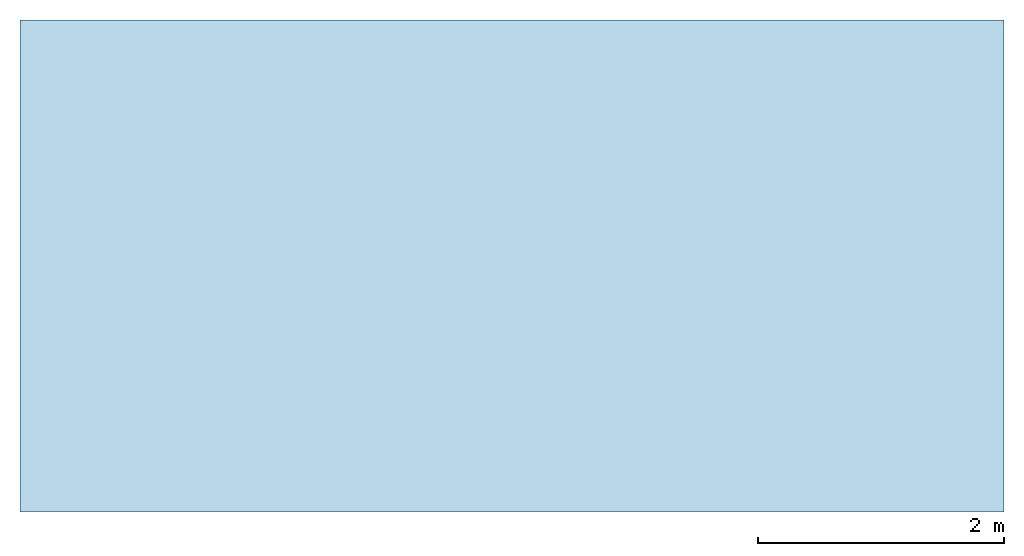
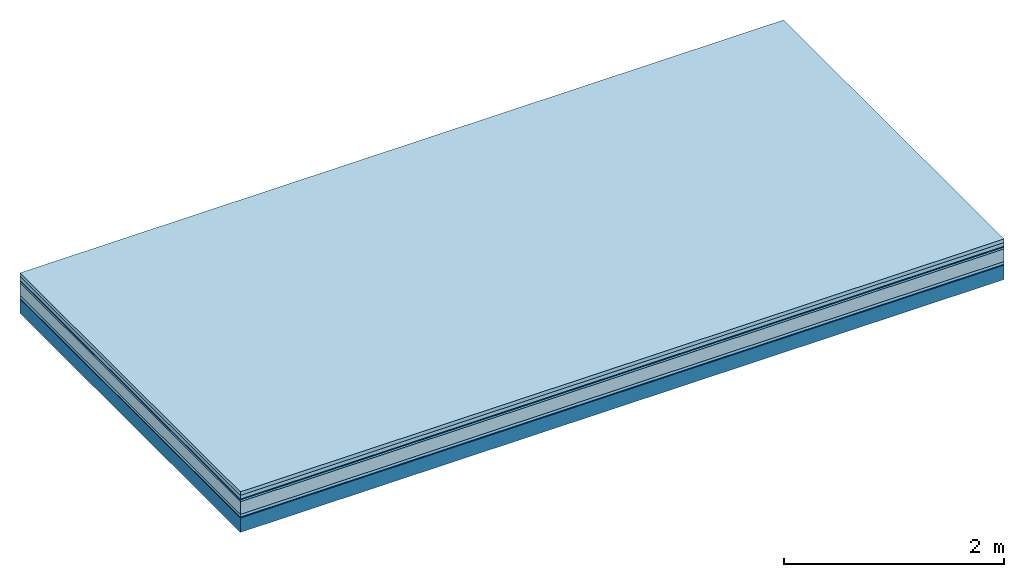
# One storey: 7 plates, 1 member, 1 element without a shape of its own.
"""IFC4 building model written with IfcOpenShell, lengths in metres."""

from ifc_helpers import new_model, si_unit, derived_unit, direction, frame, frame_2d, origin, origin_with_axes, place, context, project, spatial, rectangle, extrude, material, layer, layer_set, type_object, element, aggregate, save


model = new_model("IFC4")

# Units and contexts
plan_context = context("Plan", 3, precision=1e-05, world=origin(), true_north=direction((0.0, 1.0)))
model_context = context("Model", 3, precision=1e-05, world=origin(), true_north=direction((0.0, 1.0)))
ifc_project = project(units=[si_unit("LENGTHUNIT", "METRE"), derived_unit("SOUNDPRESSUREUNIT", [(si_unit("PRESSUREUNIT", "PASCAL", prefix="MICRO"), 0)]), si_unit("ENERGYUNIT", "JOULE", prefix="MEGA"), si_unit("MASSUNIT", "GRAM", prefix="KILO"), derived_unit("THERMALTRANSMITTANCEUNIT", [(si_unit("POWERUNIT", "WATT"), 1), (si_unit("AREAUNIT", "SQUARE_METRE"), -1), (si_unit("THERMODYNAMICTEMPERATUREUNIT", "KELVIN"), -1)]), derived_unit("AREADENSITYUNIT", [(si_unit("MASSUNIT", "GRAM", prefix="KILO"), 1), (si_unit("AREAUNIT", "SQUARE_METRE"), -1)]), derived_unit("USERDEFINED", [(si_unit("ENERGYUNIT", "JOULE", prefix="MEGA"), 1), (si_unit("AREAUNIT", "SQUARE_METRE"), -1)])], contexts=[plan_context, model_context])

# Site, building, storey
site = spatial("IfcSite", under=ifc_project)
building_placement = place(None, origin())
building = spatial("IfcBuilding", under=site, at=building_placement)
storey_placement = place(building_placement, origin())
storey = spatial("IfcBuildingStorey", under=building, at=storey_placement)

# Slab, member, plates
ifc_material_1 = material(Name="Garden plates", Category="02.007")
ifc_layer_1 = layer(ifc_material_1, 0.04, Name="Use and protection layer 3")
ifc_material_2 = material(Name="Gravel 8-16mm", Category="03.011")
ifc_layer_2 = layer(ifc_material_2, 0.04, Name="Use and protection layer 2")
ifc_material_3 = material(Name="Protective layer", Category="09.007")
ifc_layer_3 = layer(ifc_material_3, 0.01, Name="Use and protection layer 1")
ifc_material_4 = material(Name="Bituminous", Category="09.003")
ifc_layer_4 = layer(ifc_material_4, 0.02, Name="Seal")
ifc_material_5 = material(Category="10.006")
ifc_layer_5 = layer(ifc_material_5, 0.14, Name="Exterior insulation layer 2")
ifc_material_6 = material(Name="(034) 25 boards", Category="10.004")
ifc_layer_6 = layer(ifc_material_6, 0.03, Name="Exterior insulation layer 1")
ifc_material_7 = material(Name="Vapor-permeable barrier", Category="09.006")
ifc_layer_7 = layer(ifc_material_7, 0.01, Name="layer / temporary roof")
ifc_material_8 = material(Name="no composite action")
ifc_layer_8 = layer(ifc_material_8, 0.0, Name="Bond")
ifc_layer_9 = layer(None, 0.16, Name="Support")
ifc_layer_set = layer_set([ifc_layer_1, ifc_layer_2, ifc_layer_3, ifc_layer_4, ifc_layer_5, ifc_layer_6, ifc_layer_7, ifc_layer_8, ifc_layer_9])
slab_type = type_object("IfcSlabType", Name="F0061", PredefinedType="NOTDEFINED", material=ifc_layer_set)
slab_placement = place(None, frame((0.0, 0.0, 0.0), z_axis=(0.0, 0.0, -1.0), x_axis=(1.0, 0.0, 0.0)))
slab = element("IfcSlab", 1, at=slab_placement, inside=storey, type_object=slab_type, material=ifc_layer_set, Name="Slab #1")
ifc_material_9 = material(Name="Solid timber panel")
member_placement = place(slab_placement, origin())
member = element("IfcMember", 2, at=member_placement, material=ifc_material_9, Name="Support", context=plan_context, shape_type="SweptSolid", body=[
    extrude(rectangle(XDim=1.0, YDim=0.16, at=frame_2d((0.5, 0.08), x_axis=(1.0, 0.0))), frame((0.0, 4.0, 0.29), z_axis=(0.0, -1.0, 0.0), x_axis=(1.0, 0.0, 0.0)), (0.0, 0.0, 1.0), 4.0),
    extrude(rectangle(XDim=1.0, YDim=0.16, at=frame_2d((0.5, 0.08), x_axis=(1.0, 0.0))), frame((1.0, 4.0, 0.29), z_axis=(0.0, -1.0, 0.0), x_axis=(1.0, 0.0, 0.0)), (0.0, 0.0, 1.0), 4.0),
    extrude(rectangle(XDim=1.0, YDim=0.16, at=frame_2d((0.5, 0.08), x_axis=(1.0, 0.0))), frame((2.0, 4.0, 0.29), z_axis=(0.0, -1.0, 0.0), x_axis=(1.0, 0.0, 0.0)), (0.0, 0.0, 1.0), 4.0),
    extrude(rectangle(XDim=1.0, YDim=0.16, at=frame_2d((0.5, 0.08), x_axis=(1.0, 0.0))), frame((3.0, 4.0, 0.29), z_axis=(0.0, -1.0, 0.0), x_axis=(1.0, 0.0, 0.0)), (0.0, 0.0, 1.0), 4.0),
    extrude(rectangle(XDim=1.0, YDim=0.16, at=frame_2d((0.5, 0.08), x_axis=(1.0, 0.0))), frame((4.0, 4.0, 0.29), z_axis=(0.0, -1.0, 0.0), x_axis=(1.0, 0.0, 0.0)), (0.0, 0.0, 1.0), 4.0),
    extrude(rectangle(XDim=1.0, YDim=0.16, at=frame_2d((0.5, 0.08), x_axis=(1.0, 0.0))), frame((5.0, 4.0, 0.29), z_axis=(0.0, -1.0, 0.0), x_axis=(1.0, 0.0, 0.0)), (0.0, 0.0, 1.0), 4.0),
    extrude(rectangle(XDim=1.0, YDim=0.16, at=frame_2d((0.5, 0.08), x_axis=(1.0, 0.0))), frame((6.0, 4.0, 0.29), z_axis=(0.0, -1.0, 0.0), x_axis=(1.0, 0.0, 0.0)), (0.0, 0.0, 1.0), 4.0),
    extrude(rectangle(XDim=1.0, YDim=0.16, at=frame_2d((0.5, 0.08), x_axis=(1.0, 0.0))), frame((7.0, 4.0, 0.29), z_axis=(0.0, -1.0, 0.0), x_axis=(1.0, 0.0, 0.0)), (0.0, 0.0, 1.0), 4.0),
])
plate_1_placement = place(slab_placement, origin())
plate_1 = element("IfcPlate", 3, at=plate_1_placement, material=ifc_material_1, Name="Use and protection layer 3", context=plan_context, shape_type="SweptSolid", body=[
    extrude(rectangle(XDim=8.0, YDim=4.0, at=frame_2d((4.0, 2.0), x_axis=(1.0, 0.0))), origin_with_axes(), (0.0, 0.0, 1.0), 0.04),
])
plate_2_placement = place(slab_placement, origin())
plate_2 = element("IfcPlate", 4, at=plate_2_placement, material=ifc_material_2, Name="Use and protection layer 2", context=plan_context, shape_type="SweptSolid", body=[
    extrude(rectangle(XDim=8.0, YDim=4.0, at=frame_2d((4.0, 2.0), x_axis=(1.0, 0.0))), frame((0.0, 0.0, 0.04), z_axis=(0.0, 0.0, 1.0), x_axis=(1.0, 0.0, 0.0)), (0.0, 0.0, 1.0), 0.04),
])
plate_3_placement = place(slab_placement, origin())
plate_3 = element("IfcPlate", 5, at=plate_3_placement, material=ifc_material_3, Name="Use and protection layer 1", context=plan_context, shape_type="SweptSolid", body=[
    extrude(rectangle(XDim=8.0, YDim=4.0, at=frame_2d((4.0, 2.0), x_axis=(1.0, 0.0))), frame((0.0, 0.0, 0.08), z_axis=(0.0, 0.0, 1.0), x_axis=(1.0, 0.0, 0.0)), (0.0, 0.0, 1.0), 0.01),
])
plate_4_placement = place(slab_placement, origin())
plate_4 = element("IfcPlate", 6, at=plate_4_placement, material=ifc_material_4, Name="Seal", context=plan_context, shape_type="SweptSolid", body=[
    extrude(rectangle(XDim=8.0, YDim=4.0, at=frame_2d((4.0, 2.0), x_axis=(1.0, 0.0))), frame((0.0, 0.0, 0.09), z_axis=(0.0, 0.0, 1.0), x_axis=(1.0, 0.0, 0.0)), (0.0, 0.0, 1.0), 0.02),
])
plate_5_placement = place(slab_placement, origin())
plate_5 = element("IfcPlate", 7, at=plate_5_placement, material=ifc_material_5, Name="Exterior insulation layer 2", context=plan_context, shape_type="SweptSolid", body=[
    extrude(rectangle(XDim=8.0, YDim=4.0, at=frame_2d((4.0, 2.0), x_axis=(1.0, 0.0))), frame((0.0, 0.0, 0.11), z_axis=(0.0, 0.0, 1.0), x_axis=(1.0, 0.0, 0.0)), (0.0, 0.0, 1.0), 0.14),
])
plate_6_placement = place(slab_placement, origin())
plate_6 = element("IfcPlate", 8, at=plate_6_placement, material=ifc_material_6, Name="Exterior insulation layer 1", context=plan_context, shape_type="SweptSolid", body=[
    extrude(rectangle(XDim=8.0, YDim=4.0, at=frame_2d((4.0, 2.0), x_axis=(1.0, 0.0))), frame((0.0, 0.0, 0.25), z_axis=(0.0, 0.0, 1.0), x_axis=(1.0, 0.0, 0.0)), (0.0, 0.0, 1.0), 0.03),
])
plate_7_placement = place(slab_placement, origin())
plate_7 = element("IfcPlate", 9, at=plate_7_placement, material=ifc_material_7, Name="layer / temporary roof", context=plan_context, shape_type="SweptSolid", body=[
    extrude(rectangle(XDim=8.0, YDim=4.0, at=frame_2d((4.0, 2.0), x_axis=(1.0, 0.0))), frame((0.0, 0.0, 0.28), z_axis=(0.0, 0.0, 1.0), x_axis=(1.0, 0.0, 0.0)), (0.0, 0.0, 1.0), 0.01),
])
aggregate(slab, [plate_1, plate_2, plate_3, plate_4, plate_5, plate_6, plate_7, member])

save(model, "model.ifc")
